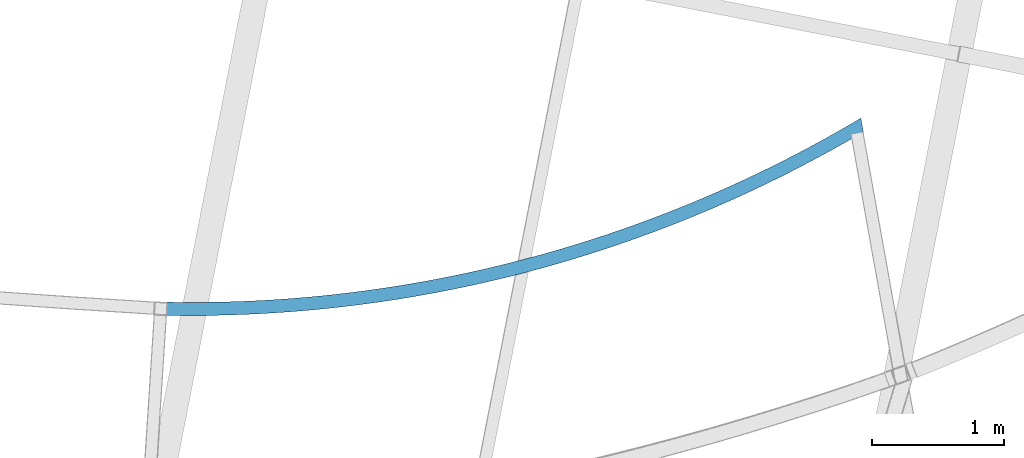
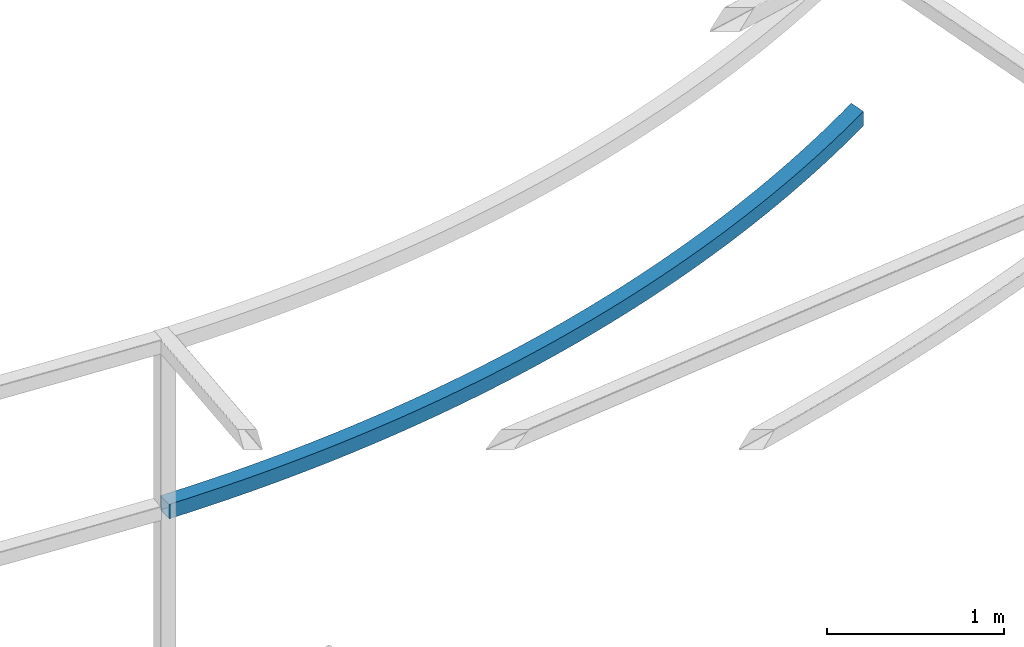
# One storey, part 209 of 215: 1 beam, 1 element without a shape of its own.
"""IFC2X3 building model written with IfcOpenShell, lengths in millimetres."""

from ifc_helpers import new_model, si_unit, frame, origin_with_axes, place, context, subcontext, project, spatial, faceted_brep, material, type_object, element, aggregate, save


model = new_model("IFC2X3")

# Units and contexts
model_context = context("Model", 3, precision=1e-05, world=origin_with_axes())
body_context = subcontext(model_context, "Body", "Model", "MODEL_VIEW")
ifc_project = project(units=[si_unit("LENGTHUNIT", "METRE", prefix="MILLI"), si_unit("AREAUNIT", "SQUARE_METRE"), si_unit("VOLUMEUNIT", "CUBIC_METRE"), si_unit("MASSUNIT", "GRAM", prefix="KILO"), si_unit("TIMEUNIT", "SECOND"), si_unit("PLANEANGLEUNIT", "RADIAN"), si_unit("SOLIDANGLEUNIT", "STERADIAN"), si_unit("THERMODYNAMICTEMPERATUREUNIT", "DEGREE_CELSIUS"), si_unit("LUMINOUSINTENSITYUNIT", "LUMEN")], contexts=[model_context])

# Site, building, storey
site_placement = place(None, origin_with_axes())
site = spatial("IfcSite", under=ifc_project, at=site_placement, CompositionType="ELEMENT")
building_placement = place(site_placement, origin_with_axes())
building = spatial("IfcBuilding", under=site, at=building_placement, Name="Undefined", CompositionType="ELEMENT")
storey_placement = place(building_placement, origin_with_axes())
storey = spatial("IfcBuildingStorey", under=building, at=storey_placement, Name="Undefined", CompositionType="ELEMENT", Elevation=0.0)

# Assembly, beam
assembly_placement = place(storey_placement, origin_with_axes())
assembly = element("IfcElementAssembly", 1, at=assembly_placement, inside=storey, Name="Steel Assembly", AssemblyPlace="NOTDEFINED", PredefinedType="RIGID_FRAME")
ifc_material = material(Name="STEEL/S275JR")
beam_type = type_object("IfcBeamType", PredefinedType="NOTDEFINED")
beam_placement = place(assembly_placement, frame((79292.5596214586, 5933.80750636546, 5610.00000147687), z_axis=(-0.254036429912331, 0.967194650666244, 0.0), x_axis=(0.967194650666242, 0.254036429912337, 0.0)))
beam = element("IfcBeam", 2, at=beam_placement, type_object=beam_type, material=ifc_material, Name="POUTRE", context=body_context, shape_type="Brep", body=[
    faceted_brep([(13.8027650535223, 50.0, 48.0570876861802), (13.8027650535223, -50.0, 48.0570876861802), (120.962516663611, -50.0, 17.926930383619), (120.962516663611, 50.0, 17.926930383619), (228.452636376329, -50.0, -11.0025166964588), (228.452636376329, 50.0, -11.0025166964588), (336.259670852232, -50.0, -38.7276327778127), (336.259670852232, 50.0, -38.7276327778127), (444.370127087197, -50.0, -65.2449478168783), (444.370127087197, 50.0, -65.2449478168783), (552.770474101198, -50.0, -90.5511429370781), (552.770474101198, 50.0, -90.5511429370781), (661.447144631748, -50.0, -114.643050844223), (661.447144631748, 50.0, -114.643050844223), (770.386536832113, -50.0, -137.517656222892), (770.386536832113, 50.0, -137.517656222892), (879.575015973576, -50.0, -159.172096113844), (879.575015973576, 50.0, -159.172096113844), (988.998916151962, -50.0, -179.603660272365), (988.998916151962, 50.0, -179.603660272365), (1098.64454199812, -50.0, -198.809791507432), (1098.64454199812, 50.0, -198.809791507432), (1208.49817039195, -50.0, -216.788086001812), (1208.49817039195, 50.0, -216.788086001812), (1318.54605217997, -50.0, -233.536293612895), (1318.54605217997, 50.0, -233.536293612895), (1428.77441389619, -50.0, -249.052318154325), (1428.77441389619, 50.0, -249.052318154325), (1539.16945948597, -50.0, -263.334217658366), (1539.16945948597, 50.0, -263.334217658366), (1649.71737203271, -50.0, -276.380204618938), (1649.71737203271, 50.0, -276.380204618938), (1760.40431548712, -50.0, -288.188646215367), (1760.40431548712, 50.0, -288.188646215367), (1871.21643639897, -50.0, -298.758064516705), (1871.21643639897, 50.0, -298.758064516705), (1982.13986565101, -50.0, -308.087136666752), (1982.13986565101, 50.0, -308.087136666752), (2093.16072019475, -50.0, -316.174695049598), (2093.16072019475, 50.0, -316.174695049598), (2204.26510478801, -50.0, -323.019727435752), (2204.26510478801, 50.0, -323.019727435752), (2315.43911373413, -50.0, -328.621377108855), (2315.43911373413, 50.0, -328.621377108855), (2426.66883262237, -50.0, -332.978942972903), (2426.66883262237, 50.0, -332.978942972903), (2537.94034006934, -50.0, -336.091879639967), (2537.94034006934, 50.0, -336.091879639967), (2649.23970946147, -50.0, -337.959797498483), (2649.23970946147, 50.0, -337.959797498483), (2760.55301069804, -50.0, -338.582462762013), (2760.55301069804, 50.0, -338.582462762013), (2871.86631193462, -50.0, -337.959797498483), (2871.86631193462, 50.0, -337.959797498483), (2983.16568132676, -50.0, -336.091879639966), (2983.16568132676, 50.0, -336.091879639966), (3094.43718877374, -50.0, -332.978942972903), (3094.43718877374, 50.0, -332.978942972903), (3205.66690766196, -50.0, -328.621377108859), (3205.66690766196, 50.0, -328.621377108859), (3316.8409166081, -50.0, -323.019727435752), (3316.8409166081, 50.0, -323.019727435752), (3427.94530120135, -50.0, -316.174695049598), (3427.94530120135, 50.0, -316.174695049598), (3538.96615574509, -50.0, -308.087136666756), (3538.96615574509, 50.0, -308.087136666756), (3649.88958499713, -50.0, -298.758064516707), (3649.88958499713, 50.0, -298.758064516707), (3760.70170590898, -50.0, -288.188646215367), (3760.70170590898, 50.0, -288.188646215367), (3871.38864936339, -50.0, -276.380204618943), (3871.38864936339, 50.0, -276.380204618943), (3981.93656191012, -50.0, -263.334217658368), (3981.93656191012, 50.0, -263.334217658368), (4092.3316074999, -50.0, -249.052318154323), (4092.3316074999, 50.0, -249.052318154323), (4202.55996921612, -50.0, -233.536293612891), (4202.55996921612, 50.0, -233.536293612891), (4312.60785100416, -50.0, -216.788086001814), (4312.60785100416, 50.0, -216.788086001814), (4422.46147939797, -50.0, -198.809791507434), (4422.46147939797, 50.0, -198.809791507434), (4532.10710524413, -50.0, -179.603660272365), (4532.10710524413, 50.0, -179.603660272365), (4641.53100542253, -50.0, -159.172096113847), (4641.53100542253, 50.0, -159.172096113847), (4750.71948456398, -50.0, -137.517656222888), (4750.71948456398, 50.0, -137.517656222888), (4859.65887676434, -50.0, -114.643050844228), (4859.65887676434, 50.0, -114.643050844228), (4968.3355472949, -50.0, -90.5511429370872), (4968.3355472949, 50.0, -90.5511429370872), (5076.73589430888, -50.0, -65.2449478168783), (5076.73589430888, 50.0, -65.2449478168783), (5184.84635054386, -50.0, -38.7276327778127), (5184.84635054386, 50.0, -38.7276327778127), (5292.65338501976, -50.0, -11.0025166964642), (5292.65338501976, 50.0, -11.0025166964642), (5400.14350473249, 50.0, 17.9269303836136), (5400.14350473249, -50.0, 17.9269303836136), (5507.30325634258, -50.0, 48.0570876861784), (5507.30325634258, 50.0, 48.0570876861784), (5318.10162998782, -50.0, -107.710255931986), (5426.67205241122, -50.0, -78.4900606400479), (5209.21110772823, -50.0, -135.714016396061), (5100.01411424468, -50.0, -162.497837113911), (4990.52431650693, -50.0, -188.05836585342), (4880.75541813184, -50.0, -212.392403488268), (4770.72115766814, -50.0, -235.496904398377), (4660.43530687704, -50.0, -257.368976851052), (4549.91166900842, -50.0, -278.005883362919), (4439.16407707335, -50.0, -297.405041042563), (4328.20639211274, -50.0, -315.564021913768), (4217.05250146255, -50.0, -332.480553219433), (4105.7163170155, -50.0, -348.152517706007), (3994.21177348007, -50.0, -362.577953888478), (3882.55282663641, -50.0, -375.755056295897), (3770.75345158949, -50.0, -387.682175697311), (3658.82764102024, -50.0, -398.35781930821), (3546.78940343398, -50.0, -407.780650977355), (3434.65276140743, -50.0, -415.949491353997), (3322.43174983331, -50.0, -422.863318035485), (3210.14041416411, -50.0, -428.521265695259), (3097.79280865387, -50.0, -432.922626191103), (2985.4029945994, -50.0, -436.066848653812), (2872.98503858023, -50.0, -437.95353955614), (2760.55301069804, -50.0, -438.582462762013), (2648.12098281589, -50.0, -437.95353955614), (2535.70302679668, -50.0, -436.066848653814), (2423.3132127422, -50.0, -432.922626191103), (2310.96560723199, -50.0, -428.521265695261), (2198.67427156278, -50.0, -422.863318035488), (2086.45325998867, -50.0, -415.949491353995), (1974.3166179621, -50.0, -407.780650977355), (1862.27838037588, -50.0, -398.35781930821), (1750.35256980661, -50.0, -387.682175697308), (1638.55319475969, -50.0, -375.755056295897), (1526.89424791602, -50.0, -362.577953888482), (1415.38970438059, -50.0, -348.152517706007), (1304.05351993356, -50.0, -332.480553219437), (1192.89962928335, -50.0, -315.564021913769), (1081.94194432274, -50.0, -297.405041042559), (971.194352387669, -50.0, -278.005883362923), (860.670714519059, -50.0, -257.368976851052), (750.38486372793, -50.0, -235.496904398373), (640.350603264247, -50.0, -212.392403488269), (530.581704889162, -50.0, -188.058365853412), (421.091907151422, -50.0, -162.497837113911), (311.894913667871, -50.0, -135.714016396065), (203.004391408278, -50.0, -107.710255931985), (94.4339689848566, -50.0, -78.4900606400461), (-13.8027650534787, -50.0, -48.0570876862002), (-13.8027650534787, 50.0, -48.0570876862002), (94.4339689848566, 50.0, -78.4900606400461), (203.004391408278, 50.0, -107.710255931985), (311.894913667871, 50.0, -135.714016396065), (421.091907151422, 50.0, -162.497837113911), (530.581704889162, 50.0, -188.058365853412), (640.350603264247, 50.0, -212.392403488269), (750.38486372793, 50.0, -235.496904398373), (860.670714519059, 50.0, -257.368976851052), (971.194352387669, 50.0, -278.005883362923), (1081.94194432274, 50.0, -297.405041042559), (1192.89962928335, 50.0, -315.564021913769), (1304.05351993356, 50.0, -332.480553219437), (1415.38970438059, 50.0, -348.152517706007), (1526.89424791602, 50.0, -362.577953888482), (1638.55319475969, 50.0, -375.755056295897), (1750.35256980661, 50.0, -387.682175697308), (1862.27838037588, 50.0, -398.35781930821), (1974.3166179621, 50.0, -407.780650977355), (2086.45325998867, 50.0, -415.949491353995), (2198.67427156278, 50.0, -422.863318035488), (2310.96560723199, 50.0, -428.521265695261), (2423.3132127422, 50.0, -432.922626191103), (2535.70302679668, 50.0, -436.066848653814), (2648.12098281589, 50.0, -437.95353955614), (2760.55301069804, 50.0, -438.582462762013), (2872.98503858023, 50.0, -437.95353955614), (2985.4029945994, 50.0, -436.066848653812), (3097.79280865387, 50.0, -432.922626191103), (3210.14041416411, 50.0, -428.521265695259), (3322.43174983331, 50.0, -422.863318035485), (3434.65276140743, 50.0, -415.949491353997), (3546.78940343398, 50.0, -407.780650977355), (3658.82764102024, 50.0, -398.35781930821), (3770.75345158949, 50.0, -387.682175697311), (3882.55282663641, 50.0, -375.755056295897), (3994.21177348007, 50.0, -362.577953888478), (4105.7163170155, 50.0, -348.152517706007), (4217.05250146255, 50.0, -332.480553219433), (4328.20639211274, 50.0, -315.564021913768), (4439.16407707335, 50.0, -297.405041042563), (4549.91166900842, 50.0, -278.005883362919), (4660.43530687704, 50.0, -257.368976851052), (4770.72115766814, 50.0, -235.496904398377), (4880.75541813184, 50.0, -212.392403488268), (4990.52431650693, 50.0, -188.05836585342), (5100.01411424468, 50.0, -162.497837113911), (5209.21110772823, 50.0, -135.714016396061), (5318.10162998782, 50.0, -107.710255931986), (5426.67205241122, 50.0, -78.4900606400479), (5501.22198712551, 50.0, -57.5288207520553), (5501.22198712551, -50.0, -57.5288207520553), (5509.12924965772, -50.0, 41.6995266815829), (5509.6916876808, -50.0, 48.7575692516257), (5509.6916876808, 50.0, 48.7575692516257), (5509.12924965772, 50.0, 41.6995266815829), (12.6985438492411, 46.0, 44.2125206712844), (12.6985438492411, -46.0, 44.2125206712844), (-12.6985438491974, -46.0, -44.2125206713063), (-12.6985438491974, 46.0, -44.2125206713063), (95.4951108920213, 46.0, -74.6333809990974), (119.90137475646, 46.0, 14.0702507426704), (119.90137475646, -46.0, 14.0702507426704), (95.4951108920213, -46.0, -74.6333809990974), (204.022321206998, -46.0, -103.841946362561), (204.022321206998, 46.0, -103.841946362561), (227.434706577609, 46.0, -14.870826265882), (227.434706577609, -46.0, -14.870826265882), (335.285080564863, -46.0, -42.6070881225442), (312.869503955226, -46.0, -131.834561051332), (312.869503955226, 46.0, -131.834561051332), (335.285080564863, 46.0, -42.6070881225442), (443.438998289785, 46.0, -69.1350633887596), (443.438998289785, -46.0, -69.1350633887596), (422.023035948863, -46.0, -158.607721542032), (422.023035948863, 46.0, -158.607721542032), (531.469255657648, 46.0, -184.158076936761), (551.882923332712, 46.0, -94.4514318537331), (551.882923332712, -46.0, -94.4514318537331), (531.469255657648, -46.0, -184.158076936761), (641.194464918954, -46.0, -208.482429382504), (641.194464918954, 46.0, -208.482429382504), (660.603282977056, 46.0, -118.553024949984), (660.603282977056, -46.0, -118.553024949984), (769.586469907954, -46.0, -141.436826149909), (751.184930652118, -46.0, -231.577734471355), (751.184930652118, 46.0, -231.577734471355), (769.586469907954, 46.0, -141.436826149909), (878.818843915389, 46.0, -163.099971343334), (878.818843915389, -46.0, -163.099971343334), (861.426886577246, -46.0, -253.44110162156), (861.426886577246, 46.0, -253.44110162156), (971.906534938258, 46.0, -274.0697944393), (988.286733601388, 46.0, -183.539749195985), (988.286733601388, -46.0, -183.539749195985), (971.906534938258, -46.0, -274.0697944393), (1082.61004822975, -46.0, -293.461231061156), (1082.61004822975, 46.0, -293.461231061156), (1097.97643809109, 46.0, -202.753601488836), (1097.97643809109, -46.0, -202.753601488836), (1207.87422874761, -46.0, -220.739123438289), (1193.52357092767, -46.0, -311.612984477291), (1193.52357092767, 46.0, -311.612984477291), (1207.87422874761, 46.0, -220.739123438289), (1317.9663508901, 46.0, -237.494063997157), (1317.9663508901, -46.0, -237.494063997157), (1304.63322122343, -46.0, -328.522782835174), (1304.63322122343, 46.0, -328.522782835174), (1415.92509276122, 46.0, -344.188509723939), (1428.23902551559, 46.0, -253.016326136392), (1428.23902551559, -46.0, -253.016326136392), (1415.92509276122, -46.0, -344.188509723939), (1527.38525637881, -46.0, -358.608204439275), (1527.38525637881, 46.0, -358.608204439275), (1538.67845102318, 46.0, -267.303967107575), (1538.67845102318, -46.0, -267.303967107575), (1649.27080494179, -46.0, -280.355198686018), (1638.99976185062, -46.0, -371.780062228816), (1638.99976185062, 46.0, -371.780062228816), (1649.27080494179, 46.0, -280.355198686018), (1760.0022456599, 46.0, -292.168387394646), (1760.0022456599, -46.0, -292.168387394646), (1750.75463963381, -46.0, -383.702434518033), (1750.75463963381, 46.0, -383.702434518033), (1862.63590261679, 46.0, -394.37382911655), (1870.85891415805, 46.0, -302.742054708368), (1870.85891415805, -46.0, -302.742054708368), (1862.63590261679, -46.0, -394.37382911655), (1974.62954786967, -46.0, -403.792910404931), (1974.62954786967, 46.0, -403.792910404931), (1981.82693574346, 46.0, -312.074877239176), (1981.82693574346, -46.0, -312.074877239176), (2092.8924217865, -46.0, -320.165686901773), (2086.72155839692, -46.0, -411.958499501819), (2086.72155839692, 46.0, -411.958499501819), (2092.8924217865, 46.0, -320.165686901773), (2204.04147145899, 46.0, -327.013471059741), (2204.04147145899, -46.0, -327.013471059741), (2198.8979048918, -46.0, -418.869574411499), (2198.8979048918, 46.0, -418.869574411499), (2311.14454749208, 46.0, -424.525270151802), (2315.26017347405, 46.0, -332.617372652316), (2315.26017347405, -46.0, -332.617372652316), (2311.14454749208, -46.0, -424.525270151802), (2423.44743753743, -46.0, -428.924878862377), (2423.44743753743, 46.0, -428.924878862377), (2426.53460782717, 46.0, -336.976690301633), (2426.53460782717, -46.0, -336.976690301633), (2537.85084753842, -46.0, -340.090878400519), (2535.7925193276, -46.0, -432.067849893265), (2535.7925193276, 46.0, -432.067849893265), (2537.85084753842, 46.0, -340.090878400519), (2649.19496039565, 46.0, -341.959547180792), (2649.19496039565, -46.0, -341.959547180792), (2648.1657318817, -46.0, -433.953789873831), (2648.1657318817, 46.0, -433.953789873831), (2760.55301069804, 46.0, -434.582462762011), (2760.55301069804, 46.0, -342.582462762013), (2760.55301069804, -46.0, -342.582462762013), (2760.55301069804, -46.0, -434.582462762011), (2872.9402895144, -46.0, -433.953789873834), (2872.9402895144, 46.0, -433.953789873834), (2871.91106100044, 46.0, -341.959547180792), (2871.91106100044, -46.0, -341.959547180792), (2983.25517385767, -46.0, -340.090878400521), (2985.3135020685, -46.0, -432.067849893261), (2985.3135020685, 46.0, -432.067849893261), (2983.25517385767, 46.0, -340.090878400521), (3094.57141356895, 46.0, -336.976690301632), (3094.57141356895, -46.0, -336.976690301632), (3097.65858385868, -46.0, -428.924878862374), (3097.65858385868, 46.0, -428.924878862374), (3209.96147390403, 46.0, -424.525270151804), (3205.84584792206, 46.0, -332.617372652316), (3205.84584792206, -46.0, -332.617372652316), (3209.96147390403, -46.0, -424.525270151804), (3322.20811650431, -46.0, -418.869574411499), (3322.20811650431, 46.0, -418.869574411499), (3317.06454993712, 46.0, -327.013471059741), (3317.06454993712, -46.0, -327.013471059741), (3428.21359960959, -46.0, -320.165686901772), (3434.38446299918, -46.0, -411.958499501818), (3434.38446299918, 46.0, -411.958499501818), (3428.21359960959, 46.0, -320.165686901772), (3539.27908565263, 46.0, -312.074877239178), (3539.27908565263, -46.0, -312.074877239178), (3546.47647352643, -46.0, -403.792910404929), (3546.47647352643, 46.0, -403.792910404929), (3658.47011877931, 46.0, -394.373829116554), (3650.24710723804, 46.0, -302.742054708368), (3650.24710723804, -46.0, -302.742054708368), (3658.47011877931, -46.0, -394.373829116554), (3770.35138176229, -46.0, -383.702434518034), (3770.35138176229, 46.0, -383.702434518034), (3761.10377573621, 46.0, -292.168387394644), (3761.10377573621, -46.0, -292.168387394644), (3871.8352164543, -46.0, -280.355198686018), (3882.10625954547, -46.0, -371.780062228818), (3882.10625954547, 46.0, -371.780062228818), (3871.8352164543, 46.0, -280.355198686018), (3982.42757037292, 46.0, -267.303967107571), (3982.42757037292, -46.0, -267.303967107571), (3993.72076501729, -46.0, -358.608204439279), (3993.72076501729, 46.0, -358.608204439279), (4105.18092863486, 46.0, -344.188509723937), (4092.86699588053, 46.0, -253.016326136394), (4092.86699588053, -46.0, -253.016326136394), (4105.18092863486, -46.0, -344.188509723937), (4216.47280017269, -46.0, -328.522782835178), (4216.47280017269, 46.0, -328.522782835178), (4203.13967050599, 46.0, -237.494063997154), (4203.13967050599, -46.0, -237.494063997154), (4313.23179264851, -46.0, -220.739123438296), (4327.58245046841, -46.0, -311.612984477295), (4327.58245046841, 46.0, -311.612984477295), (4313.23179264851, 46.0, -220.739123438296), (4423.129583305, 46.0, -202.753601488839), (4423.129583305, -46.0, -202.753601488839), (4438.49597316634, -46.0, -293.461231061156), (4438.49597316634, 46.0, -293.461231061156), (4549.19948645784, 46.0, -274.0697944393), (4532.81928779471, 46.0, -183.539749195988), (4532.81928779471, -46.0, -183.539749195988), (4549.19948645784, -46.0, -274.0697944393), (4659.67913481886, -46.0, -253.44110162156), (4659.67913481886, 46.0, -253.44110162156), (4642.2871774807, 46.0, -163.099971343334), (4642.2871774807, -46.0, -163.099971343334), (4751.51955148813, -46.0, -141.436826149911), (4769.921090744, -46.0, -231.577734471359), (4769.921090744, 46.0, -231.577734471359), (4751.51955148813, 46.0, -141.436826149911), (4860.50273841903, 46.0, -118.553024949988), (4860.50273841903, -46.0, -118.553024949988), (4879.91155647715, -46.0, -208.482429382508), (4879.91155647715, 46.0, -208.482429382508), (4989.63676573845, 46.0, -184.158076936761), (4969.22309806338, 46.0, -94.4514318537367), (4969.22309806338, -46.0, -94.4514318537367), (4989.63676573845, -46.0, -184.158076936761), (5099.08298544724, -46.0, -158.60772154203), (5099.08298544724, 46.0, -158.60772154203), (5077.6670231063, 46.0, -69.1350633887596), (5077.6670231063, -46.0, -69.1350633887596), (5185.82094083124, -46.0, -42.607088122546), (5208.23651744086, -46.0, -131.834561051332), (5208.23651744086, 46.0, -131.834561051332), (5185.82094083124, 46.0, -42.607088122546), (5293.67131481848, 46.0, -14.8708262658838), (5293.67131481848, -46.0, -14.8708262658838), (5317.08370018911, -46.0, -103.841946362561), (5317.08370018911, 46.0, -103.841946362561), (5425.61091050407, 46.0, -74.6333809991011), (5401.20464663963, 46.0, 14.0702507426668), (5401.20464663963, -46.0, 14.0702507426668), (5508.40747754686, 46.0, 44.2125206712863), (5508.40747754686, -46.0, 44.2125206712863), (5425.61091050407, -46.0, -74.6333809991011), (5501.56068083542, -46.0, -53.2785486782577), (5501.56068083542, 46.0, -53.2785486782577), (5509.12924965771, 46.0, 41.6995266815848), (5509.35156814911, 46.0, 44.4894045207056), (5509.35156814911, -46.0, 44.4894045207056), (5509.12924965771, -46.0, 41.6995266815848)], [[[0, 1, 2, 3]], [[3, 2, 4, 5]], [[5, 4, 6, 7]], [[7, 6, 8, 9]], [[9, 8, 10, 11]], [[11, 10, 12, 13]], [[13, 12, 14, 15]], [[15, 14, 16, 17]], [[17, 16, 18, 19]], [[19, 18, 20, 21]], [[21, 20, 22, 23]], [[23, 22, 24, 25]], [[25, 24, 26, 27]], [[27, 26, 28, 29]], [[29, 28, 30, 31]], [[31, 30, 32, 33]], [[33, 32, 34, 35]], [[35, 34, 36, 37]], [[37, 36, 38, 39]], [[39, 38, 40, 41]], [[41, 40, 42, 43]], [[43, 42, 44, 45]], [[45, 44, 46, 47]], [[47, 46, 48, 49]], [[49, 48, 50, 51]], [[51, 50, 52, 53]], [[53, 52, 54, 55]], [[55, 54, 56, 57]], [[57, 56, 58, 59]], [[59, 58, 60, 61]], [[61, 60, 62, 63]], [[63, 62, 64, 65]], [[65, 64, 66, 67]], [[67, 66, 68, 69]], [[69, 68, 70, 71]], [[71, 70, 72, 73]], [[73, 72, 74, 75]], [[75, 74, 76, 77]], [[77, 76, 78, 79]], [[79, 78, 80, 81]], [[81, 80, 82, 83]], [[83, 82, 84, 85]], [[85, 84, 86, 87]], [[87, 86, 88, 89]], [[89, 88, 90, 91]], [[91, 90, 92, 93]], [[93, 92, 94, 95]], [[95, 94, 96, 97]], [[98, 99, 100, 101]], [[97, 96, 99, 98]], [[96, 102, 103, 99]], [[94, 104, 102, 96]], [[92, 105, 104, 94]], [[90, 106, 105, 92]], [[88, 107, 106, 90]], [[86, 108, 107, 88]], [[84, 109, 108, 86]], [[82, 110, 109, 84]], [[80, 111, 110, 82]], [[78, 112, 111, 80]], [[76, 113, 112, 78]], [[74, 114, 113, 76]], [[72, 115, 114, 74]], [[70, 116, 115, 72]], [[68, 117, 116, 70]], [[66, 118, 117, 68]], [[64, 119, 118, 66]], [[62, 120, 119, 64]], [[60, 121, 120, 62]], [[58, 122, 121, 60]], [[56, 123, 122, 58]], [[54, 124, 123, 56]], [[52, 125, 124, 54]], [[50, 126, 125, 52]], [[48, 127, 126, 50]], [[46, 128, 127, 48]], [[44, 129, 128, 46]], [[42, 130, 129, 44]], [[40, 131, 130, 42]], [[38, 132, 131, 40]], [[36, 133, 132, 38]], [[34, 134, 133, 36]], [[32, 135, 134, 34]], [[30, 136, 135, 32]], [[28, 137, 136, 30]], [[26, 138, 137, 28]], [[24, 139, 138, 26]], [[22, 140, 139, 24]], [[20, 141, 140, 22]], [[18, 142, 141, 20]], [[16, 143, 142, 18]], [[14, 144, 143, 16]], [[12, 145, 144, 14]], [[10, 146, 145, 12]], [[8, 147, 146, 10]], [[6, 148, 147, 8]], [[4, 149, 148, 6]], [[2, 150, 149, 4]], [[1, 151, 150, 2]], [[151, 152, 153, 150]], [[150, 153, 154, 149]], [[149, 154, 155, 148]], [[148, 155, 156, 147]], [[147, 156, 157, 146]], [[146, 157, 158, 145]], [[145, 158, 159, 144]], [[144, 159, 160, 143]], [[143, 160, 161, 142]], [[142, 161, 162, 141]], [[141, 162, 163, 140]], [[140, 163, 164, 139]], [[139, 164, 165, 138]], [[138, 165, 166, 137]], [[137, 166, 167, 136]], [[136, 167, 168, 135]], [[135, 168, 169, 134]], [[134, 169, 170, 133]], [[133, 170, 171, 132]], [[132, 171, 172, 131]], [[131, 172, 173, 130]], [[130, 173, 174, 129]], [[129, 174, 175, 128]], [[128, 175, 176, 127]], [[127, 176, 177, 126]], [[126, 177, 178, 125]], [[125, 178, 179, 124]], [[124, 179, 180, 123]], [[123, 180, 181, 122]], [[122, 181, 182, 121]], [[121, 182, 183, 120]], [[120, 183, 184, 119]], [[119, 184, 185, 118]], [[118, 185, 186, 117]], [[117, 186, 187, 116]], [[116, 187, 188, 115]], [[115, 188, 189, 114]], [[114, 189, 190, 113]], [[113, 190, 191, 112]], [[112, 191, 192, 111]], [[111, 192, 193, 110]], [[110, 193, 194, 109]], [[109, 194, 195, 108]], [[108, 195, 196, 107]], [[107, 196, 197, 106]], [[106, 197, 198, 105]], [[105, 198, 199, 104]], [[104, 199, 200, 102]], [[102, 200, 201, 103]], [[103, 201, 202, 203]], [[100, 99, 103, 203, 204]], [[100, 204, 205]], [[101, 100, 205, 206]], [[101, 206, 207]], [[201, 98, 101, 207, 202]], [[200, 97, 98, 201]], [[199, 95, 97, 200]], [[198, 93, 95, 199]], [[197, 91, 93, 198]], [[196, 89, 91, 197]], [[195, 87, 89, 196]], [[194, 85, 87, 195]], [[193, 83, 85, 194]], [[192, 81, 83, 193]], [[191, 79, 81, 192]], [[190, 77, 79, 191]], [[189, 75, 77, 190]], [[188, 73, 75, 189]], [[187, 71, 73, 188]], [[186, 69, 71, 187]], [[185, 67, 69, 186]], [[184, 65, 67, 185]], [[183, 63, 65, 184]], [[182, 61, 63, 183]], [[181, 59, 61, 182]], [[180, 57, 59, 181]], [[179, 55, 57, 180]], [[178, 53, 55, 179]], [[177, 51, 53, 178]], [[176, 49, 51, 177]], [[175, 47, 49, 176]], [[174, 45, 47, 175]], [[173, 43, 45, 174]], [[172, 41, 43, 173]], [[171, 39, 41, 172]], [[170, 37, 39, 171]], [[169, 35, 37, 170]], [[168, 33, 35, 169]], [[167, 31, 33, 168]], [[166, 29, 31, 167]], [[165, 27, 29, 166]], [[164, 25, 27, 165]], [[163, 23, 25, 164]], [[162, 21, 23, 163]], [[161, 19, 21, 162]], [[160, 17, 19, 161]], [[159, 15, 17, 160]], [[158, 13, 15, 159]], [[157, 11, 13, 158]], [[156, 9, 11, 157]], [[155, 7, 9, 156]], [[154, 5, 7, 155]], [[153, 3, 5, 154]], [[152, 0, 3, 153]], [[151, 1, 0, 152], [208, 209, 210, 211]], [[208, 211, 212, 213]], [[209, 208, 213, 214]], [[210, 209, 214, 215]], [[211, 210, 215, 212]], [[212, 215, 216, 217]], [[213, 212, 217, 218]], [[214, 213, 218, 219]], [[215, 214, 219, 216]], [[216, 219, 220, 221]], [[217, 216, 221, 222]], [[218, 217, 222, 223]], [[219, 218, 223, 220]], [[220, 223, 224, 225]], [[221, 220, 225, 226]], [[222, 221, 226, 227]], [[223, 222, 227, 224]], [[224, 227, 228, 229]], [[225, 224, 229, 230]], [[226, 225, 230, 231]], [[227, 226, 231, 228]], [[228, 231, 232, 233]], [[229, 228, 233, 234]], [[230, 229, 234, 235]], [[231, 230, 235, 232]], [[232, 235, 236, 237]], [[233, 232, 237, 238]], [[234, 233, 238, 239]], [[235, 234, 239, 236]], [[236, 239, 240, 241]], [[237, 236, 241, 242]], [[238, 237, 242, 243]], [[239, 238, 243, 240]], [[240, 243, 244, 245]], [[241, 240, 245, 246]], [[242, 241, 246, 247]], [[243, 242, 247, 244]], [[244, 247, 248, 249]], [[245, 244, 249, 250]], [[246, 245, 250, 251]], [[247, 246, 251, 248]], [[248, 251, 252, 253]], [[249, 248, 253, 254]], [[250, 249, 254, 255]], [[251, 250, 255, 252]], [[252, 255, 256, 257]], [[253, 252, 257, 258]], [[254, 253, 258, 259]], [[255, 254, 259, 256]], [[256, 259, 260, 261]], [[257, 256, 261, 262]], [[258, 257, 262, 263]], [[259, 258, 263, 260]], [[260, 263, 264, 265]], [[261, 260, 265, 266]], [[262, 261, 266, 267]], [[263, 262, 267, 264]], [[264, 267, 268, 269]], [[265, 264, 269, 270]], [[266, 265, 270, 271]], [[267, 266, 271, 268]], [[268, 271, 272, 273]], [[269, 268, 273, 274]], [[270, 269, 274, 275]], [[271, 270, 275, 272]], [[272, 275, 276, 277]], [[273, 272, 277, 278]], [[274, 273, 278, 279]], [[275, 274, 279, 276]], [[276, 279, 280, 281]], [[277, 276, 281, 282]], [[278, 277, 282, 283]], [[279, 278, 283, 280]], [[280, 283, 284, 285]], [[281, 280, 285, 286]], [[282, 281, 286, 287]], [[283, 282, 287, 284]], [[284, 287, 288, 289]], [[285, 284, 289, 290]], [[286, 285, 290, 291]], [[287, 286, 291, 288]], [[288, 291, 292, 293]], [[289, 288, 293, 294]], [[290, 289, 294, 295]], [[291, 290, 295, 292]], [[292, 295, 296, 297]], [[293, 292, 297, 298]], [[294, 293, 298, 299]], [[295, 294, 299, 296]], [[296, 299, 300, 301]], [[297, 296, 301, 302]], [[298, 297, 302, 303]], [[299, 298, 303, 300]], [[300, 303, 304, 305]], [[301, 300, 305, 306]], [[302, 301, 306, 307]], [[303, 302, 307, 304]], [[304, 307, 308, 309]], [[305, 304, 309, 310]], [[306, 305, 310, 311]], [[307, 306, 311, 308]], [[308, 311, 312, 313]], [[309, 308, 313, 314]], [[310, 309, 314, 315]], [[311, 310, 315, 312]], [[312, 315, 316, 317]], [[313, 312, 317, 318]], [[314, 313, 318, 319]], [[315, 314, 319, 316]], [[316, 319, 320, 321]], [[317, 316, 321, 322]], [[318, 317, 322, 323]], [[319, 318, 323, 320]], [[320, 323, 324, 325]], [[321, 320, 325, 326]], [[322, 321, 326, 327]], [[323, 322, 327, 324]], [[324, 327, 328, 329]], [[325, 324, 329, 330]], [[326, 325, 330, 331]], [[327, 326, 331, 328]], [[328, 331, 332, 333]], [[329, 328, 333, 334]], [[330, 329, 334, 335]], [[331, 330, 335, 332]], [[332, 335, 336, 337]], [[333, 332, 337, 338]], [[334, 333, 338, 339]], [[335, 334, 339, 336]], [[336, 339, 340, 341]], [[337, 336, 341, 342]], [[338, 337, 342, 343]], [[339, 338, 343, 340]], [[340, 343, 344, 345]], [[341, 340, 345, 346]], [[342, 341, 346, 347]], [[343, 342, 347, 344]], [[344, 347, 348, 349]], [[345, 344, 349, 350]], [[346, 345, 350, 351]], [[347, 346, 351, 348]], [[348, 351, 352, 353]], [[349, 348, 353, 354]], [[350, 349, 354, 355]], [[351, 350, 355, 352]], [[352, 355, 356, 357]], [[353, 352, 357, 358]], [[354, 353, 358, 359]], [[355, 354, 359, 356]], [[356, 359, 360, 361]], [[357, 356, 361, 362]], [[358, 357, 362, 363]], [[359, 358, 363, 360]], [[360, 363, 364, 365]], [[361, 360, 365, 366]], [[362, 361, 366, 367]], [[363, 362, 367, 364]], [[364, 367, 368, 369]], [[365, 364, 369, 370]], [[366, 365, 370, 371]], [[367, 366, 371, 368]], [[368, 371, 372, 373]], [[369, 368, 373, 374]], [[370, 369, 374, 375]], [[371, 370, 375, 372]], [[372, 375, 376, 377]], [[373, 372, 377, 378]], [[374, 373, 378, 379]], [[375, 374, 379, 376]], [[376, 379, 380, 381]], [[377, 376, 381, 382]], [[378, 377, 382, 383]], [[379, 378, 383, 380]], [[380, 383, 384, 385]], [[381, 380, 385, 386]], [[382, 381, 386, 387]], [[383, 382, 387, 384]], [[384, 387, 388, 389]], [[385, 384, 389, 390]], [[386, 385, 390, 391]], [[387, 386, 391, 388]], [[388, 391, 392, 393]], [[389, 388, 393, 394]], [[390, 389, 394, 395]], [[391, 390, 395, 392]], [[392, 395, 396, 397]], [[393, 392, 397, 398]], [[394, 393, 398, 399]], [[395, 394, 399, 396]], [[396, 399, 400, 401]], [[397, 396, 401, 402]], [[398, 397, 402, 403]], [[399, 398, 403, 400]], [[400, 403, 404, 405]], [[406, 405, 407, 408]], [[401, 400, 405, 406]], [[402, 401, 406, 409]], [[403, 402, 409, 404]], [[404, 409, 410, 411]], [[407, 405, 404, 411, 412]], [[407, 412, 413]], [[408, 407, 413, 414]], [[408, 414, 415]], [[409, 406, 408, 415, 410]], [[207, 206, 205, 204, 203, 202], [414, 413, 412, 411, 410, 415]]]),
])
aggregate(assembly, [beam])

save(model, "model.ifc")
